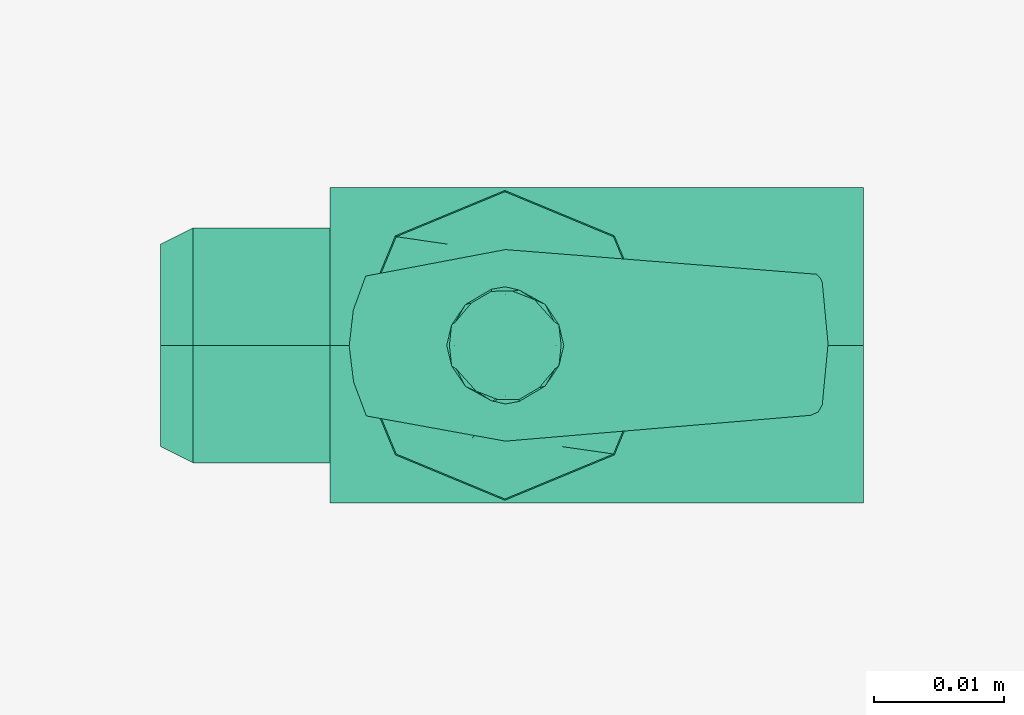
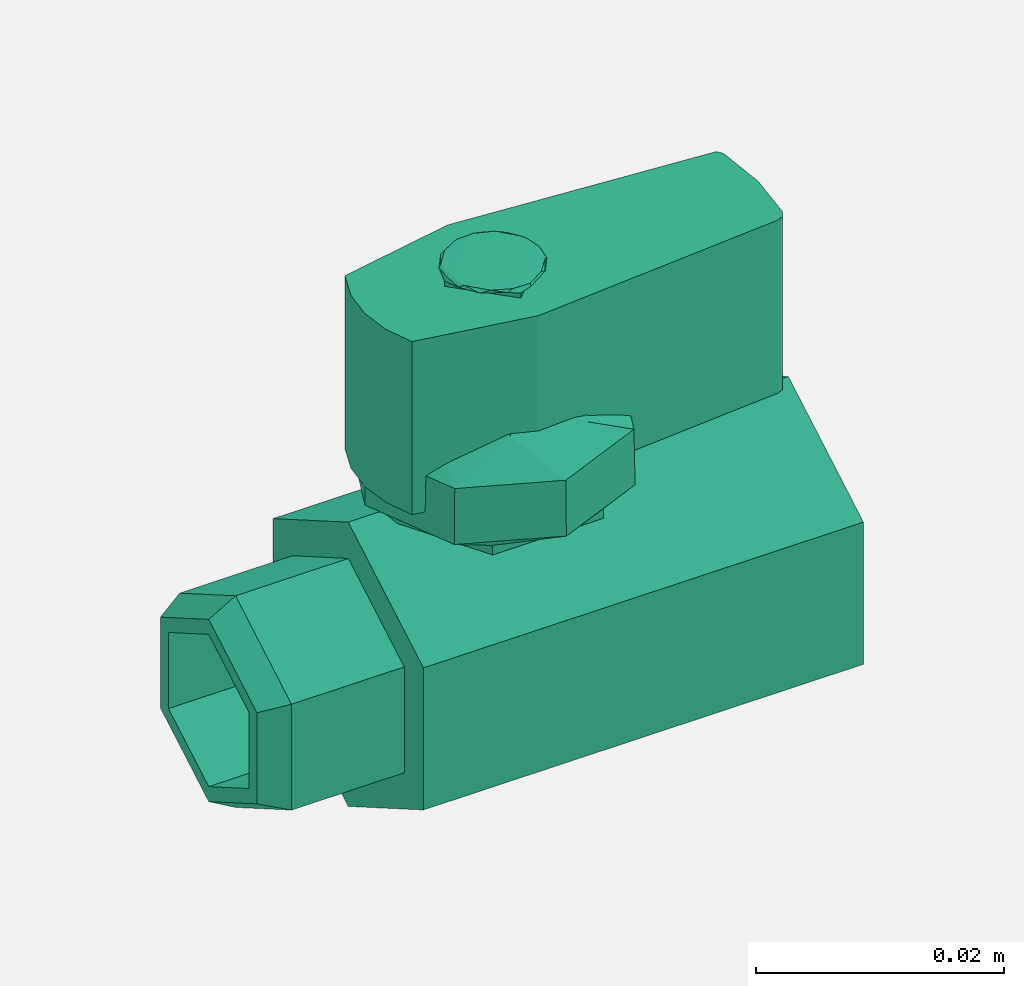
# One storey, part 2 of 2: 1 flow terminal.
"""IFC2X3 building model written with IfcOpenShell, lengths in metres."""

import ifcopenshell
import ifcopenshell.guid

model = None  # the IFC model being written
_history = None  # IfcOwnerHistory: only IFC2X3 demands one
_inside = {}  # id of a spatial element -> (the spatial element, [elements in it])
_under = {}  # id of a project, library or spatial element -> (it, [spatial elements below it])
_declared = {}  # id of a project -> (the project, [libraries it declares])
_typed = {}  # id of a type object -> (the type object, [elements of that type])
_made_of = {}  # id of a material, layer set ... -> (it, [elements and type objects made of it])


def new_model(schema):
    """Start an empty IFC model of exactly this schema.

    Asked for "IFC4X3", IfcOpenShell would pick the latest addendum, in which some entities
    have other attributes; the version numbers below select the first issue.
    IFC2X3 requires an IfcOwnerHistory on every rooted entity: one is made here for all.
    """
    global model, _history
    if schema == "IFC4X3":
        model = ifcopenshell.file(schema_version=(4, 3, 0, 0))
    else:
        model = ifcopenshell.file(schema=schema)
    _inside.clear()
    _under.clear()
    _declared.clear()
    _typed.clear()
    _made_of.clear()
    _history = None
    if model.schema == "IFC2X3":
        org = make("IfcOrganization", Name="unknown")
        user = make(
            "IfcPersonAndOrganization",
            ThePerson=make("IfcPerson", FamilyName="unknown"),
            TheOrganization=org,
        )
        app = make(
            "IfcApplication",
            ApplicationDeveloper=org,
            Version="unknown",
            ApplicationFullName="unknown",
            ApplicationIdentifier="unknown",
        )
        _history = make(
            "IfcOwnerHistory",
            OwningUser=user,
            OwningApplication=app,
            ChangeAction="ADDED",
            CreationDate=0,
        )
    return model


def make(cls, **values):
    """One entity of the class cls with the attributes given. An attribute that is None is left unset."""
    return model.create_entity(
        cls, **{name: value for name, value in values.items() if value is not None}
    )


def entity(cls, *values):
    """Any entity or typed value of the class cls, its attributes in the order of the schema. None: left unset."""
    e = model.create_entity(cls)
    for i, value in enumerate(values):
        if value is not None:
            e[i] = value
    return e


def rooted(cls, **values):
    """An entity with a GlobalId (a new one), such as an element, a storey or a relation."""
    return make(cls, GlobalId=ifcopenshell.guid.new(), OwnerHistory=_history, **values)


def si_unit(unit_type, name, prefix=None):
    """IfcSIUnit, for example si_unit("LENGTHUNIT", "METRE", prefix="MILLI")."""
    return make("IfcSIUnit", UnitType=unit_type, Prefix=prefix, Name=name)


def converted_unit(unit_type, name, factor, base, dimensions=None, offset=None):
    """IfcConversionBasedUnit, such as the inch: factor (a typed value) times the base unit."""
    return make(
        "IfcConversionBasedUnit"
        if offset is None
        else "IfcConversionBasedUnitWithOffset",
        ConversionOffset=offset,
        Dimensions=None
        if dimensions is None
        else entity("IfcDimensionalExponents", *dimensions),
        UnitType=unit_type,
        Name=name,
        ConversionFactor=make(
            "IfcMeasureWithUnit", ValueComponent=factor, UnitComponent=base
        ),
    )


def derived_unit(unit_type, elements):
    """IfcDerivedUnit: a product of units, each with its exponent."""
    return make(
        "IfcDerivedUnit",
        Elements=[
            make("IfcDerivedUnitElement", Unit=unit, Exponent=power)
            for unit, power in elements
        ],
        UnitType=unit_type,
    )


def assignment(units):
    """IfcUnitAssignment: the units of a project."""
    return None if units is None else make("IfcUnitAssignment", Units=units)


def point(xyz):
    """IfcCartesianPoint."""
    return None if xyz is None else make("IfcCartesianPoint", Coordinates=xyz)


def direction(xyz):
    """IfcDirection."""
    return None if xyz is None else make("IfcDirection", DirectionRatios=xyz)


def frame(location, z_axis=None, x_axis=None):
    """IfcAxis2Placement3D, a coordinate frame: its origin and axes. An axis left out is left unset."""
    return make(
        "IfcAxis2Placement3D",
        Location=point(location),
        Axis=direction(z_axis),
        RefDirection=direction(x_axis),
    )


def origin():
    """The frame at (0, 0, 0) with its axes left unset."""
    return frame((0.0, 0.0, 0.0))


def place(relative_to, where):
    """IfcLocalPlacement: puts the frame where relative to a parent placement (None: the world)."""
    return make(
        "IfcLocalPlacement", PlacementRelTo=relative_to, RelativePlacement=where
    )


def context(
    kind, dimensions, precision=None, world=None, true_north=None, identifier=None
):
    """IfcGeometricRepresentationContext, for example the 3D "Model" context."""
    return make(
        "IfcGeometricRepresentationContext",
        ContextIdentifier=identifier,
        ContextType=kind,
        CoordinateSpaceDimension=dimensions,
        Precision=precision,
        WorldCoordinateSystem=world,
        TrueNorth=true_north,
    )


def subcontext(parent, identifier, kind, view, scale=None):
    """IfcGeometricRepresentationSubContext, for example "Body" below "Model"."""
    return make(
        "IfcGeometricRepresentationSubContext",
        ContextIdentifier=identifier,
        ContextType=kind,
        ParentContext=parent,
        TargetScale=scale,
        TargetView=view,
    )


def project(units=None, contexts=None):
    """IfcProject with its units and contexts."""
    return rooted(
        "IfcProject",
        Name="project",
        RepresentationContexts=contexts,
        UnitsInContext=assignment(units),
    )


def spatial(cls, under=None, at=None, **own):
    """A site, building, storey or space (cls), placed at a placement, below another one or the project."""
    s = rooted(cls, ObjectPlacement=at, **own)
    if under is not None:
        _under.setdefault(under.id(), (under, []))[1].append(s)
    return s


def faces_of(points, faces, orient=None, outer=None):
    """IfcFace entities. A face is a list of loops; a loop is a list of indices into points, from 0.

    orient and outer hold one flag for each loop. By default every Orientation is true, the
    first loop of a face is its IfcFaceOuterBound and the others are IfcFaceBound.
    """
    made = []
    for i, loops in enumerate(faces):
        bounds = []
        for j, loop in enumerate(loops):
            is_outer = j == 0 if outer is None else outer[i][j]
            bounds.append(
                make(
                    "IfcFaceOuterBound" if is_outer else "IfcFaceBound",
                    Bound=make("IfcPolyLoop", Polygon=[points[k] for k in loop]),
                    Orientation=True if orient is None else orient[i][j],
                )
            )
        made.append(make("IfcFace", Bounds=bounds))
    return made


def faceted_brep(points, faces, orient=None, outer=None, voids=None):
    """IfcFacetedBrep: a solid bounded by flat faces; with voids (closed shells), ...WithVoids."""
    shared = [point(p) for p in points]
    hull = make("IfcClosedShell", CfsFaces=faces_of(shared, faces, orient, outer))
    if voids is None:
        return make("IfcFacetedBrep", Outer=hull)
    return make(
        "IfcFacetedBrepWithVoids",
        Outer=hull,
        Voids=[
            make(cls, CfsFaces=faces_of(shared, fs, o, b)) for cls, fs, o, b in voids
        ],
    )


def shape(context_of_items, identifier, shape_type, items):
    """IfcShapeRepresentation: the items that make up one representation, for example the "Body"."""
    return make(
        "IfcShapeRepresentation",
        ContextOfItems=context_of_items,
        RepresentationIdentifier=identifier,
        RepresentationType=shape_type,
        Items=items,
    )


def source(mapping_origin, context_of_items, identifier, shape_type, items):
    """IfcRepresentationMap: a shape defined once, which mapped items show again and again."""
    return make(
        "IfcRepresentationMap",
        MappingOrigin=mapping_origin,
        MappedRepresentation=shape(context_of_items, identifier, shape_type, items),
    )


def transform(
    local_origin,
    x_axis=None,
    y_axis=None,
    z_axis=None,
    scale=None,
    scale2=None,
    scale3=None,
    uniform=True,
):
    """IfcCartesianTransformationOperator3D, or its non-uniform kind. x_axis, y_axis, z_axis: its Axis1, 2, 3."""
    if uniform:
        return make(
            "IfcCartesianTransformationOperator3D",
            Axis1=direction(x_axis),
            Axis2=direction(y_axis),
            LocalOrigin=point(local_origin),
            Scale=scale,
            Axis3=direction(z_axis),
        )
    return make(
        "IfcCartesianTransformationOperator3DnonUniform",
        Axis1=direction(x_axis),
        Axis2=direction(y_axis),
        LocalOrigin=point(local_origin),
        Scale=scale,
        Axis3=direction(z_axis),
        Scale2=scale2,
        Scale3=scale3,
    )


def mapped(mapping_source, mapping_target):
    """IfcMappedItem: shows the shape of a source again, moved by a transform."""
    return make(
        "IfcMappedItem", MappingSource=mapping_source, MappingTarget=mapping_target
    )


def material(Name=None, Category=None):
    """IfcMaterial."""
    return make("IfcMaterial", Name=Name, Category=Category)


def material_list(materials):
    """IfcMaterialList."""
    return make("IfcMaterialList", Materials=materials)


def made_of(thing, what):
    """Note that an element or type object is made of a material, layer set ...; save() writes the relation."""
    if what is not None:
        _made_of.setdefault(what.id(), (what, []))[1].append(thing)
    return thing


def element(
    cls,
    number,
    at=None,
    inside=None,
    cuts=None,
    type_object=None,
    material=None,
    context=None,
    identifier="Body",
    shape_type=None,
    held_by="IfcProductDefinitionShape",
    body=None,
    shapes=None,
    **own,
):
    """One element of the class cls, such as IfcWall. Its Tag is "e" and its number.

    at: its placement. inside: the storey or other place that contains it. cuts: it is an
    opening in that element (IfcRelVoidsElement). A single representation is given by context,
    identifier, shape_type and body (its items); several are given by shapes. held_by: the class
    of the entity that holds the representations. save() writes the other relations.
    """
    e = rooted(cls, Tag="e%d" % number, ObjectPlacement=at, **own)
    if body is not None:
        shapes = [shape(context, identifier, shape_type, body)]
    if shapes is not None:
        e.Representation = make(held_by, Representations=shapes)
    if inside is not None:
        _inside.setdefault(inside.id(), (inside, []))[1].append(e)
    if cuts is not None:
        rooted(
            "IfcRelVoidsElement", RelatingBuildingElement=cuts, RelatedOpeningElement=e
        )
    if type_object is not None:
        _typed.setdefault(type_object.id(), (type_object, []))[1].append(e)
    return made_of(e, material)


def aggregate(whole, parts):
    """IfcRelAggregates: a whole, such as a stair, and the parts it consists of."""
    return rooted("IfcRelAggregates", RelatingObject=whole, RelatedObjects=parts)


def save(model, path):
    """Write the relations noted so far, then the file.

    IfcRelAggregates (storeys below a building ...), IfcRelContainedInSpatialStructure (elements
    in a storey), IfcRelDefinesByType, IfcRelAssociatesMaterial and IfcRelDeclares: one each for
    every whole, place, type object, material and project.
    """
    for whole, parts in _under.values():
        aggregate(whole, parts)
    for where, things in _inside.values():
        rooted(
            "IfcRelContainedInSpatialStructure",
            RelatedElements=things,
            RelatingStructure=where,
        )
    for kind, things in _typed.values():
        rooted("IfcRelDefinesByType", RelatedObjects=things, RelatingType=kind)
    for what, things in _made_of.values():
        rooted("IfcRelAssociatesMaterial", RelatedObjects=things, RelatingMaterial=what)
    for by, libraries in _declared.values():
        rooted("IfcRelDeclares", RelatingContext=by, RelatedDefinitions=libraries)
    model.write(path)


model = new_model("IFC2X3")

# Units and contexts
model_context = context("Model", 3, precision=1e-05, world=origin(), true_north=direction((6.12303176911189e-17, 1.0)))
body_context = subcontext(model_context, "Body", "Model", "MODEL_VIEW")
ifc_project = project(units=[si_unit("LENGTHUNIT", "METRE"), si_unit("AREAUNIT", "SQUARE_METRE"), si_unit("VOLUMEUNIT", "CUBIC_METRE"), converted_unit("PLANEANGLEUNIT", "DEGREE", entity("IfcRatioMeasure", 0.0174532925199433), si_unit("PLANEANGLEUNIT", "RADIAN"), dimensions=[0, 0, 0, 0, 0, 0, 0]), si_unit("MASSUNIT", "GRAM", prefix="KILO"), derived_unit("MASSDENSITYUNIT", [(si_unit("MASSUNIT", "GRAM", prefix="KILO"), 1), (si_unit("LENGTHUNIT", "METRE"), -3)]), si_unit("TIMEUNIT", "SECOND"), si_unit("FREQUENCYUNIT", "HERTZ"), si_unit("THERMODYNAMICTEMPERATUREUNIT", "DEGREE_CELSIUS"), derived_unit("THERMALTRANSMITTANCEUNIT", [(si_unit("MASSUNIT", "GRAM", prefix="KILO"), 1), (si_unit("THERMODYNAMICTEMPERATUREUNIT", "KELVIN"), -1), (si_unit("TIMEUNIT", "SECOND"), -3)]), derived_unit("VOLUMETRICFLOWRATEUNIT", [(si_unit("LENGTHUNIT", "METRE"), 3), (si_unit("TIMEUNIT", "SECOND"), -1)]), si_unit("ELECTRICCURRENTUNIT", "AMPERE"), si_unit("ELECTRICVOLTAGEUNIT", "VOLT"), si_unit("POWERUNIT", "WATT"), si_unit("FORCEUNIT", "NEWTON", prefix="KILO"), si_unit("ILLUMINANCEUNIT", "LUX"), si_unit("LUMINOUSFLUXUNIT", "LUMEN"), si_unit("LUMINOUSINTENSITYUNIT", "CANDELA"), derived_unit("USERDEFINED", [(si_unit("MASSUNIT", "GRAM", prefix="KILO"), -1), (si_unit("LENGTHUNIT", "METRE"), -2), (si_unit("TIMEUNIT", "SECOND"), 3), (si_unit("LUMINOUSFLUXUNIT", "LUMEN"), 1)]), derived_unit("LINEARVELOCITYUNIT", [(si_unit("LENGTHUNIT", "METRE"), 1), (si_unit("TIMEUNIT", "SECOND"), -1)]), si_unit("PRESSUREUNIT", "PASCAL"), derived_unit("USERDEFINED", [(si_unit("LENGTHUNIT", "METRE"), -2), (si_unit("MASSUNIT", "GRAM", prefix="KILO"), 1), (si_unit("TIMEUNIT", "SECOND"), -2)])], contexts=[model_context])

# Site, building, storey
site_placement = place(None, origin())
site = spatial("IfcSite", under=ifc_project, at=site_placement, CompositionType="ELEMENT")
building_placement = place(site_placement, origin())
building = spatial("IfcBuilding", under=site, at=building_placement, CompositionType="ELEMENT")
storey_placement = place(building_placement, origin())
storey = spatial("IfcBuildingStorey", under=building, at=storey_placement, Name="0 - Piano Terra", CompositionType="ELEMENT", Elevation=0.0)

# Flow terminal
ifc_material_1 = material(Name="di")
ifc_material_2 = material(Name="di")
ifc_material_list = material_list([ifc_material_1, ifc_material_2])
shared_shape = source(origin(), body_context, "Body", "Brep", [
    faceted_brep([(-0.0255487652073473, 0.0, 0.0244215742840053), (-0.0255487652073473, 0.00902534807737502, 0.0192107871420027), (-0.0280479546178211, 0.00777413298078605, 0.018488397769173), (-0.0280479546178211, 0.0, 0.0229767955383457), (-0.0255487652073474, 0.00902534807737503, 0.00878921285799767), (-0.0280479546178211, 0.00777413298078606, 0.00951160223082744), (-0.0255487652073474, 0.0, 0.00357842571599511), (-0.0280479546178211, 0.0, 0.00502320446165465), (-0.0255487652073474, -0.009025348077375, 0.00878921285799761), (-0.0280479546178211, -0.00777413298078603, 0.00951160223082739), (-0.0255487652073473, -0.00902534807737504, 0.0192107871420027), (-0.0280479546178211, -0.00777413298078607, 0.0184883977691729), (-0.0280479546178211, 0.0, 0.00650000000000019), (-0.0280479546178211, -0.00649519052838327, 0.0102500000000002), (-0.0280479546178211, -0.00649519052838331, 0.0177500000000002), (-0.0280479546178211, 0.0, 0.0215000000000002), (-0.0280479546178211, 0.00649519052838329, 0.0177500000000002), (-0.0280479546178211, 0.0064951905283833, 0.0102500000000002), (-0.0150429137012487, 0.00649519052838329, 0.0177500000000002), (-0.0150429137012487, 0.0, 0.0215000000000002), (-0.0150429137012487, 0.0064951905283833, 0.0102500000000002), (-0.0150429137012488, 0.0, 0.00650000000000016), (-0.0150429137012487, -0.00649519052838327, 0.0102500000000001), (-0.0150429137012487, -0.0064951905283833, 0.0177500000000001), (-0.0150429137012488, 0.00903045515545773, 0.00878626428509182), (-0.0150429137012488, 0.0, 0.00357252857018344), (-0.0150429137012487, 0.00903045515545772, 0.0192137357149085), (-0.0150429137012487, 0.0, 0.0244274714298169), (-0.0150429137012487, -0.00903045515545775, 0.0192137357149085), (-0.0150429137012488, -0.00903045515545769, 0.00878626428509176)], [[[0, 1, 2, 3]], [[1, 4, 5, 2]], [[4, 6, 7, 5]], [[6, 8, 9, 7]], [[8, 10, 11, 9]], [[10, 0, 3, 11]], [[7, 12, 5]], [[12, 7, 9]], [[9, 13, 12]], [[13, 9, 14]], [[11, 14, 9]], [[14, 11, 15]], [[3, 15, 11]], [[15, 3, 2]], [[16, 2, 5]], [[2, 16, 15]], [[17, 5, 12]], [[5, 17, 16]], [[16, 18, 19, 15]], [[16, 17, 20, 18]], [[12, 21, 20, 17]], [[13, 22, 21, 12]], [[13, 14, 23, 22]], [[15, 19, 23, 14]], [[24, 21, 25]], [[21, 24, 20]], [[18, 20, 24]], [[24, 26, 18]], [[19, 18, 26]], [[26, 27, 19]], [[28, 19, 27]], [[19, 28, 23]], [[29, 23, 28]], [[21, 22, 29]], [[23, 29, 22]], [[29, 25, 21]], [[27, 26, 1, 0]], [[26, 24, 4, 1]], [[24, 25, 6, 4]], [[25, 29, 8, 6]], [[29, 28, 10, 8]], [[28, 27, 0, 10]]]),
    faceted_brep([(0.0218973370464952, -0.00537413791404711, 0.0480886370059106), (0.0224822894849931, -0.0051207205870984, 0.0480886370059106), (0.0227952586441334, -0.00456534683697189, 0.0480886370059106), (0.0232393506005107, 0.000125855583852454, 0.0480886370059106), (0.0227952586441334, 0.0048170580046768, 0.0480886370059106), (0.0226451082410602, 0.00518405666384996, 0.0480886370059106), (0.0223641263401205, 0.00546384646123757, 0.0480886370059106), (-0.00154942710562666, 0.00735890958644693, 0.0480886370059106), (-0.0122859403674836, 0.00532487874705553, 0.0480886370059106), (-0.0132396879857867, 0.00271061673559408, 0.0480886370059106), (-0.0135549747116863, -5.4269277329567e-05, 0.0480886370059106), (-0.0132142806399743, -0.00281613964602713, 0.0480886370059106), (-0.0122365375154753, -0.00542152229863007, 0.0480886370059106), (-0.0015497091776774, -0.00735813381191615, 0.0480886370059106), (0.0223641263401205, 0.00546384646123757, 0.0310451789387871), (0.0226451082410602, 0.00518405666384996, 0.0310451789387871), (0.0227952586441334, 0.0048170580046768, 0.0310451789387871), (0.0232393506005107, 0.000125855583852454, 0.0310451789387871), (0.0227952586441334, -0.00456534683697189, 0.0310451789387871), (0.0224822894849931, -0.0051207205870984, 0.0310451789387871), (0.0218973370464952, -0.00537413791404711, 0.0310451789387871), (-0.0015497091776774, -0.00735813381191615, 0.0310451789387871), (-0.0122365375154753, -0.00542152229863007, 0.0310451789387871), (-0.0132142806399743, -0.00281613964602713, 0.0310451789387871), (-0.0135549747116863, -5.4269277329567e-05, 0.0310451789387871), (-0.0132396879857867, 0.00271061673559408, 0.0310451789387871), (-0.0122859403674836, 0.00532487874705553, 0.0310451789387871), (-0.00154942710562666, 0.00735890958644693, 0.0310451789387871), (0.0218973370464952, -0.00537413791404711, 0.0354098101605602), (0.0218973370464952, -0.00537413791404711, 0.0393593756453375), (0.0218973370464952, -0.00537413791404711, 0.0437240057841375), (0.0224822894835419, -0.00512072058840563, 0.0356689490084318), (0.0227952586441334, -0.00456534683697194, 0.0438277724891298), (0.0224773963590603, -0.00512509899394969, 0.0415416910169293), (0.0227952586441333, -0.00456534683697198, 0.0395669079723489), (0.0227952586441333, -0.00456534683697201, 0.0354098101913025), (0.0227952586441334, 0.0048170580046768, 0.0352022769865576), (0.0227952586441334, 0.0048170580046768, 0.039359375034328), (0.0227952586441334, 0.0048170580046768, 0.0437240060201193), (0.0226429395293137, 0.00518729648202304, 0.0345467378898363), (0.0226394416565544, 0.00519246504201524, 0.0374883595096021), (0.0223641263401205, 0.00546384646123757, 0.035409810007347), (0.0223641263401205, 0.00546384646123757, 0.0395669079723489), (0.0226451082278381, 0.005184056683686, 0.0446252738836957), (0.0226451082478562, 0.00518405665365458, 0.0416454572492295), (0.0223641263401205, 0.00546384646123757, 0.0437240059373507)], [[[0, 1, 2, 3, 4, 5, 6, 7, 8, 9, 10, 11, 12, 13]], [[14, 15, 16, 17, 18, 19, 20, 21, 22, 23, 24, 25, 26, 27]], [[13, 21, 20, 28, 29, 30, 0]], [[19, 31, 29, 28]], [[32, 1, 33]], [[33, 34, 32]], [[19, 18, 35, 34, 31]], [[2, 1, 32]], [[1, 0, 30]], [[20, 19, 28]], [[30, 33, 1]], [[29, 33, 30]], [[34, 33, 31]], [[29, 31, 33]], [[3, 2, 32, 34, 35, 18, 17]], [[17, 16, 36, 37, 38, 4, 3]], [[36, 39, 40]], [[40, 41, 42]], [[6, 5, 43]], [[38, 37, 44]], [[38, 44, 43]], [[41, 40, 39]], [[45, 44, 42]], [[45, 43, 44]], [[14, 41, 39]], [[4, 38, 43]], [[15, 39, 16]], [[40, 44, 37]], [[6, 43, 45]], [[4, 43, 5]], [[44, 40, 42]], [[36, 40, 37]], [[16, 39, 36]], [[14, 39, 15]], [[7, 6, 45, 42, 41, 14, 27]], [[8, 7, 27, 26]], [[26, 25, 9, 8]], [[9, 25, 24, 10]], [[24, 23, 11, 10]], [[23, 22, 12, 11]], [[13, 12, 22, 21]]]),
    faceted_brep([(0.00293645174139641, 0.0, 0.0470587656938763), (-0.00156354825860361, 0.0, 0.0470587656938763), (-0.00156354825860361, 0.00450000000000001, 0.0470587656938763), (-0.00156354825860358, -0.00450000000000001, 0.0470587656938763), (-0.00606354825860361, 0.0, 0.0470587656938763), (-0.0015635482586036, 0.0, 0.049098756424123), (0.00233079168876184, 0.0, 0.049098756424123), (0.00076753362384952, 0.00156325806491232, 0.049098756424123), (-0.000398007317377042, 0.00272879900613888, 0.049098756424123), (-0.0015635482586036, 0.00389433994736543, 0.049098756424123), (-0.00351071823228632, 0.00194716997368272, 0.049098756424123), (-0.00545788820596903, 0.0, 0.049098756424123), (-0.00389463013923383, -0.00156325806673521, 0.049098756424123), (0.000383621715079128, -0.00194716997368271, 0.049098756424123), (-0.00156354825860358, -0.00389433994736543, 0.049098756424123), (-0.00272908919891871, -0.00272879900705032, 0.049098756424123), (-0.00585497697214844, 0.0, 0.048953034603562), (-0.00539153606488215, 0.00180085748265831, 0.0489985795780952), (-0.00569167347298872, 0.0015540892110554, 0.0488164680296558), (0.00293645174139641, 0.0, 0.0485850504249891), (0.00137319368253037, 0.00156325805886605, 0.0485850504249891), (0.00255378507174578, 0.00157831577198815, 0.0488187699935525), (-0.00462550924893938, 0.00313215281215, 0.0488601254291264), (-0.00293703214255305, 0.00312651611605056, 0.0485850504249891), (-0.00450029020057833, 0.00156325805802528, 0.0485850504249891), (0.00272788045494124, 0.0, 0.048953034603562), (0.00218643157086099, 0.00183459726120872, 0.0490309990107962), (-0.00263388894252603, 0.00431011338374533, 0.0487641439816079), (-0.00156354825860361, 0.00450000000000001, 0.0485850504249891), (0.00150135285759261, 0.0031524130850702, 0.0488376476701754), (0.00067256907737681, 0.00351722180816703, 0.0490344543237063), (-0.000190064376335672, 0.00312651611773208, 0.0485850504249891), (-0.000493958203830547, 0.00425218281587638, 0.0488542784760797), (-0.000999691077686441, 0.00416419542180106, 0.0490159832239193), (-0.00417619976393943, 0.00324882461000394, 0.0490338713720325), (-0.00263095564190081, 0.00415656130468368, 0.0489530346037523), (-0.0060635482586036, 0.0, 0.0485850504249891), (0.00226443954813871, -0.00180085747973747, 0.0489985795786341), (0.0025645769544725, -0.00155408921367309, 0.0488164680301276), (-0.00450029019930215, -0.00156325805930146, 0.0485850504249891), (-0.00568088158833953, -0.00157831577362457, 0.0488187699935326), (0.0014984127345083, -0.0031321528090096, 0.0488601254295213), (-0.000190064372568523, -0.00312651611396494, 0.0485850504249891), (0.00137319368441394, -0.00156325805698246, 0.0485850504249891), (-0.00531352808561889, -0.00183459726741238, 0.0490309990105261), (-0.000493207571567597, -0.00431011338297912, 0.0487641439815947), (-0.00156354825860358, -0.00450000000000001, 0.0485850504249891), (-0.00462844937094125, -0.00315241308904795, 0.0488376476699443), (-0.00379966558724698, -0.00351722181260633, 0.0490344543238009), (-0.00293703214000071, -0.00312651611860289, 0.0485850504249891), (-0.00263313830854695, -0.00425218281703117, 0.048854278476157), (-0.00212740543132995, -0.00416419542255952, 0.0490159832241207), (0.00104910324806777, -0.00324882460864377, 0.049033871372144), (-0.000496140870278897, -0.00415656130321632, 0.0489530346038971)], [[[0, 1, 2]], [[0, 3, 1]], [[4, 1, 3]], [[4, 2, 1]], [[5, 6, 7]], [[5, 7, 8]], [[5, 8, 9]], [[5, 9, 10]], [[5, 10, 11]], [[5, 11, 12]], [[5, 13, 6]], [[5, 14, 13]], [[5, 12, 15]], [[5, 15, 14]], [[16, 17, 18]], [[19, 20, 21]], [[22, 23, 24]], [[25, 26, 6]], [[27, 28, 23]], [[26, 29, 30]], [[31, 29, 20]], [[30, 7, 26]], [[32, 33, 30]], [[34, 17, 10]], [[28, 27, 32]], [[32, 29, 31]], [[32, 31, 28]], [[22, 35, 27]], [[29, 32, 30]], [[21, 20, 29]], [[33, 32, 35]], [[33, 8, 30]], [[34, 9, 35]], [[6, 26, 7]], [[26, 25, 21]], [[34, 35, 22]], [[36, 16, 18]], [[17, 34, 22]], [[26, 21, 29]], [[19, 21, 25]], [[18, 22, 24]], [[9, 34, 10]], [[16, 11, 17]], [[10, 17, 11]], [[22, 18, 17]], [[36, 18, 24]], [[22, 27, 23]], [[32, 27, 35]], [[35, 9, 33]], [[8, 33, 9]], [[8, 7, 30]], [[25, 37, 38]], [[36, 39, 40]], [[41, 42, 43]], [[16, 44, 11]], [[45, 46, 42]], [[44, 47, 48]], [[49, 47, 39]], [[48, 12, 44]], [[50, 51, 48]], [[52, 37, 13]], [[46, 45, 50]], [[50, 47, 49]], [[50, 49, 46]], [[41, 53, 45]], [[47, 50, 48]], [[40, 39, 47]], [[51, 50, 53]], [[51, 15, 48]], [[52, 14, 53]], [[11, 44, 12]], [[44, 16, 40]], [[52, 53, 41]], [[19, 25, 38]], [[37, 52, 41]], [[44, 40, 47]], [[36, 40, 16]], [[38, 41, 43]], [[14, 52, 13]], [[25, 6, 37]], [[13, 37, 6]], [[41, 38, 37]], [[19, 38, 43]], [[41, 45, 42]], [[50, 45, 53]], [[53, 14, 51]], [[15, 51, 14]], [[15, 12, 48]], [[4, 36, 24, 23, 28, 2]], [[0, 2, 28, 31, 20, 19]], [[0, 19, 43, 42, 46, 3]], [[4, 3, 46, 49, 39, 36]]]),
    faceted_brep([(-0.00994121587588156, 0.00834746587588157, 0.0345828315479619), (-0.00959398571026971, 0.0, 0.036517131767819), (-0.00604519015102338, 0.00778769429771302, 0.0363258741275504), (-0.00159375, 0.0118050994531183, 0.0345828315479619), (-0.00576748293794078, 0.0100762826645, 0.0345828315479619), (-0.0116903251410879, 0.00412474256574788, 0.0345828315479619), (-0.0133988494531183, 0.0, 0.0345828315479619), (-0.0123876614171842, 0.0, 0.0350968949605875), (-0.0113764734089167, 0.0, 0.0356109583591481), (-0.00159374994964423, 0.00449455691566894, 0.0378631700673184), (0.000901835612750102, 0.00712622477782926, 0.036956319863695), (-0.00781149801162272, 0.0, 0.0374233051764899), (0.00675371587588158, 0.0083474658758816, 0.0345828315479619), (0.00257998293794079, 0.0100762826645, 0.0345828315479619), (-0.00159374999999997, 0.0, 0.0382147571517272), (0.0015151240058114, 0.0, 0.0378190311641085), (0.00920016136543598, 0.0, 0.035096894986895), (0.0102113494531184, 0.0, 0.0345828315479619), (0.00935708726497937, 0.00206237136042768, 0.0345828315479619), (0.00850282507684038, 0.00412474272085532, 0.0345828315479619), (0.00462399801162278, 0.0, 0.0374233051764899), (0.00640648570961322, 0.0, 0.0365171317681527), (0.0081889732777536, 0.0, 0.0356109584258282), (-0.00470262400581135, 0.0, 0.0378190311641085), (0.00675371587588163, -0.00834746587588154, 0.0345828315479619), (0.00285769000065025, -0.00778769427392748, 0.0363258741747929), (-0.00159374999999992, -0.0118050994531183, 0.0345828315479619), (0.00257998293794086, -0.0100762826644999, 0.0345828315479619), (0.00850282515530275, -0.00412474253143042, 0.0345828315479619), (-0.00159375000984012, -0.00449455710389722, 0.0378631700288916), (-0.00408933577303505, -0.00712622481690542, 0.0369563198282678), (-0.00994121587588151, -0.00834746587588162, 0.0345828315479619), (-0.00576748293794072, -0.0100762826645, 0.0345828315479619), (-0.0125445873029569, -0.00206237126874174, 0.0345828315479619), (-0.0116903251527955, -0.0041247425374834, 0.0345828315479619), (-0.0134938731597981, 0.0, 0.0291389270382665), (-0.0100084077832483, 0.0084146577832483, 0.0291389270382665), (-0.00159375000000001, 0.0119001231597981, 0.0291389270382665), (0.0068209077832483, 0.00841465778324832, 0.0291389270382664), (0.0103063731597981, 0.0, 0.0291389270382664), (0.00682090778324835, -0.00841465778324826, 0.0291389270382665), (-0.00159374999999993, -0.0119001231597981, 0.0291389270382665), (-0.0100084077832482, -0.00841465778324835, 0.0291389270382665), (-0.0119114326211016, 0.0, 0.0282253045672735), (-0.00675259131055078, 0.00893537525805917, 0.0282253045672735), (-0.00933201196582617, 0.00446768762902959, 0.0282253045672735), (0.00356509131055078, 0.00893537525805919, 0.0282253045672735), (0.00872393262110159, 0.0, 0.0282253045672735), (0.00705045477384332, 0.00289854865679232, 0.0282253045672734), (0.00537697692658505, 0.00579709731358461, 0.0282253045672734), (-0.00159375, 0.00893537525805918, 0.0282253045672735), (0.00356509131055084, -0.00893537525805915, 0.0282253045672735), (0.00614451196582621, -0.00446768762902956, 0.0282253045672734), (-0.00675259131055073, -0.0089353752580592, 0.0282253045672735), (-0.0102379547754318, -0.0028985486540409, 0.0282253045672735), (-0.00856447692976211, -0.00579709730808174, 0.0282253045672735), (-0.00159374999999995, -0.00893537525805918, 0.0282253045672735), (-0.00675259131055079, 0.00893537525805917, 0.0272799574545882), (-0.00856447692437696, 0.00579709731740911, 0.0272799574545882), (-0.0102379547727393, 0.00289854865870455, 0.0272799574545882), (-0.0119114326211016, 0.0, 0.0272799574545882), (0.00356509131055078, 0.00893537525805919, 0.0272799574545881), (-0.00159375, 0.00893537525805918, 0.0272799574545882), (0.00614451196582618, 0.0044676876290296, 0.0272799574545881), (0.00872393262110159, 0.0, 0.0272799574545881), (0.00356509131055083, -0.00893537525805915, 0.0272799574545881), (0.00537697692957568, -0.0057970973084047, 0.0272799574545881), (0.00705045477533863, -0.00289854865420233, 0.0272799574545881), (-0.00675259131055073, -0.0089353752580592, 0.0272799574545882), (-0.00159374999999995, -0.00893537525805918, 0.0272799574545882), (-0.00933201196582615, -0.00446768762902963, 0.0272799574545882), (-0.00159375000000001, 0.0, 0.0272799574545882)], [[[0, 1, 2]], [[2, 3, 4, 0]], [[5, 6, 7, 8, 1, 0]], [[2, 9, 10]], [[2, 1, 11]], [[10, 12, 13, 3]], [[9, 14, 15]], [[9, 15, 10]], [[16, 17, 18, 19, 12, 20, 21, 22]], [[2, 11, 23]], [[2, 10, 3]], [[15, 20, 10]], [[2, 23, 9]], [[12, 10, 20]], [[14, 9, 23]], [[24, 21, 25]], [[25, 26, 27, 24]], [[28, 17, 16, 22, 21, 24]], [[25, 29, 30]], [[25, 21, 20]], [[30, 31, 32, 26]], [[29, 14, 23]], [[29, 23, 30]], [[33, 34, 31, 11, 1, 8, 7, 6]], [[25, 20, 15]], [[25, 30, 26]], [[23, 11, 30]], [[25, 15, 29]], [[31, 30, 11]], [[14, 29, 15]], [[35, 6, 5, 0, 36]], [[36, 0, 4, 3, 37]], [[38, 12, 19, 18, 17, 39]], [[12, 38, 37, 3, 13]], [[39, 17, 28, 24, 40]], [[40, 24, 27, 26, 41]], [[42, 31, 34, 33, 6, 35]], [[31, 42, 41, 26, 32]], [[35, 36, 43]], [[36, 44, 45, 43]], [[36, 37, 44]], [[37, 38, 46]], [[38, 47, 48, 49, 46]], [[47, 38, 39]], [[37, 46, 50, 44]], [[39, 40, 47]], [[40, 51, 52, 47]], [[40, 41, 51]], [[41, 42, 53]], [[42, 43, 54, 55, 53]], [[43, 42, 35]], [[41, 53, 56, 51]], [[44, 57, 58, 59, 60, 43, 45]], [[50, 46, 61, 62, 57, 44]], [[63, 61, 46, 49, 48, 47, 64]], [[51, 65, 66, 67, 64, 47, 52]], [[56, 53, 68, 69, 65, 51]], [[70, 68, 53, 55, 54, 43, 60]], [[71, 61, 63]], [[71, 63, 64]], [[71, 64, 67]], [[71, 62, 61]], [[71, 57, 62]], [[71, 58, 57]], [[71, 59, 58]], [[71, 60, 59]], [[71, 67, 66]], [[71, 66, 65]], [[71, 65, 69]], [[71, 70, 60]], [[71, 68, 70]], [[71, 69, 68]]]),
    faceted_brep([(0.0259570927468513, 0.00375000000000003, 0.00750480947161672), (0.0259570927468513, 0.0, 0.0), (0.0259570927468513, 0.0121243556529821, 0.00699999999999994), (0.0259570927468513, 0.00194114283826894, 0.00675555630283199), (0.0259570927468513, 0.00530330085889912, 0.00869669914110091), (0.0259570927468513, 0.0, 0.0065), (0.0259570927468513, -0.00194114283826887, 0.00675555630283198), (0.0259570927468513, -0.00374999999999997, 0.00750480947161669), (0.0259570927468513, -0.0121243556529822, 0.00700000000000004), (0.0259570927468513, -0.00530330085889908, 0.00869669914110086), (0.0259570927468513, -0.00649519052838327, 0.01025), (0.0259570927468513, -0.007244443697168, 0.012058857161731), (0.0259570927468513, -0.0075, 0.014), (0.0259570927468513, -0.0121243556529821, 0.021), (0.0259570927468513, -0.00724444369716801, 0.0159411428382689), (0.0259570927468513, -0.00649519052838329, 0.01775), (0.0259570927468513, -0.00530330085889911, 0.0193033008588991), (0.0259570927468513, -0.00375000000000001, 0.0204951905283833), (0.0259570927468513, 0.0, 0.028), (0.0259570927468513, -0.00194114283826891, 0.021244443697168), (0.0259570927468513, 0.0, 0.0215), (0.0259570927468513, 0.00194114283826889, 0.021244443697168), (0.0259570927468513, 0.00374999999999999, 0.0204951905283833), (0.0259570927468513, 0.0121243556529822, 0.0209999999999999), (0.0259570927468513, 0.00530330085889909, 0.0193033008588991), (0.0259570927468513, 0.00649519052838328, 0.01775), (0.0259570927468513, 0.00724444369716801, 0.0159411428382689), (0.0259570927468513, 0.0075, 0.014), (0.0259570927468513, 0.00724444369716802, 0.0120588571617311), (0.0259570927468513, 0.0064951905283833, 0.01025), (-0.0150429137012487, 0.00374999999999999, 0.0204951905283833), (-0.0150429137012487, 0.0, 0.028), (-0.0150429137012487, 0.0121243556529822, 0.0209999999999999), (-0.0150429137012487, 0.00194114283826889, 0.021244443697168), (-0.0150429137012487, 0.00530330085889909, 0.0193033008588991), (-0.0150429137012487, 0.0, 0.0215), (-0.0150429137012487, -0.00194114283826891, 0.021244443697168), (-0.0150429137012487, -0.00375000000000001, 0.0204951905283833), (-0.0150429137012487, -0.0121243556529821, 0.021), (-0.0150429137012487, -0.00530330085889911, 0.0193033008588991), (-0.0150429137012487, -0.00649519052838329, 0.01775), (-0.0150429137012487, -0.00724444369716801, 0.0159411428382689), (-0.0150429137012487, -0.0075, 0.014), (-0.0150429137012487, -0.0121243556529822, 0.00700000000000004), (-0.0150429137012487, -0.007244443697168, 0.012058857161731), (-0.0150429137012487, -0.00649519052838327, 0.01025), (-0.0150429137012487, -0.00530330085889908, 0.00869669914110086), (-0.0150429137012487, -0.00374999999999997, 0.00750480947161669), (-0.0150429137012487, 0.0, 0.0), (-0.0150429137012487, -0.00194114283826887, 0.00675555630283198), (-0.0150429137012487, 0.0, 0.0065), (-0.0150429137012487, 0.00194114283826894, 0.00675555630283199), (-0.0150429137012487, 0.00375000000000003, 0.00750480947161672), (-0.0150429137012487, 0.0121243556529821, 0.00699999999999994), (-0.0150429137012487, 0.00530330085889912, 0.00869669914110091), (-0.0150429137012487, 0.0064951905283833, 0.01025), (-0.0150429137012487, 0.00724444369716802, 0.0120588571617311), (-0.0150429137012487, 0.0075, 0.014), (-0.0150429137012487, 0.00724444369716801, 0.0159411428382689), (-0.0150429137012487, 0.00649519052838328, 0.01775)], [[[0, 1, 2]], [[1, 0, 3]], [[0, 2, 4]], [[5, 1, 3]], [[1, 5, 6]], [[7, 1, 6]], [[1, 7, 8]], [[7, 9, 8]], [[9, 10, 8]], [[10, 11, 8]], [[8, 11, 12]], [[12, 13, 8]], [[12, 14, 13]], [[15, 13, 14]], [[15, 16, 13]], [[17, 13, 16]], [[13, 17, 18]], [[19, 18, 17]], [[18, 19, 20]], [[18, 20, 21]], [[21, 22, 18]], [[18, 22, 23]], [[23, 22, 24]], [[24, 25, 23]], [[25, 26, 23]], [[26, 27, 23]], [[27, 28, 2]], [[2, 23, 27]], [[28, 29, 2]], [[29, 4, 2]], [[30, 31, 32]], [[31, 30, 33]], [[30, 32, 34]], [[35, 31, 33]], [[31, 35, 36]], [[37, 31, 36]], [[31, 37, 38]], [[37, 39, 38]], [[39, 40, 38]], [[40, 41, 38]], [[38, 41, 42]], [[42, 43, 38]], [[42, 44, 43]], [[45, 43, 44]], [[45, 46, 43]], [[47, 43, 46]], [[43, 47, 48]], [[49, 48, 47]], [[48, 49, 50]], [[48, 50, 51]], [[51, 52, 48]], [[48, 52, 53]], [[53, 52, 54]], [[54, 55, 53]], [[55, 56, 53]], [[56, 57, 53]], [[57, 58, 32]], [[32, 53, 57]], [[58, 59, 32]], [[59, 34, 32]], [[27, 57, 56, 28]], [[28, 56, 55, 29]], [[0, 4, 54, 52]], [[55, 54, 4, 29]], [[3, 0, 52, 51]], [[50, 5, 3, 51]], [[6, 49, 47, 7]], [[7, 47, 46, 9]], [[11, 10, 45, 44]], [[46, 45, 10, 9]], [[12, 11, 44, 42]], [[6, 5, 50, 49]], [[12, 42, 41, 14]], [[14, 41, 40, 15]], [[17, 16, 39, 37]], [[40, 39, 16, 15]], [[19, 17, 37, 36]], [[35, 20, 19, 36]], [[22, 21, 33, 30]], [[22, 30, 34, 24]], [[26, 25, 59, 58]], [[34, 59, 25, 24]], [[27, 26, 58, 57]], [[21, 20, 35, 33]], [[8, 13, 38, 43]], [[1, 8, 43, 48]], [[2, 1, 48, 53]], [[23, 2, 53, 32]], [[18, 23, 32, 31]], [[13, 18, 31, 38]]]),
])
flow_terminal_placement = place(storey_placement, frame((3.286838428494, 2.32936791847101, 0.0)))
element("IfcFlowTerminal", 1, at=flow_terminal_placement, inside=storey, material=ifc_material_list, context=body_context, shape_type="MappedRepresentation", body=[
    mapped(shared_shape, transform((0.0, 0.0, 0.0), scale=1.0)),
])

save(model, "model.ifc")
